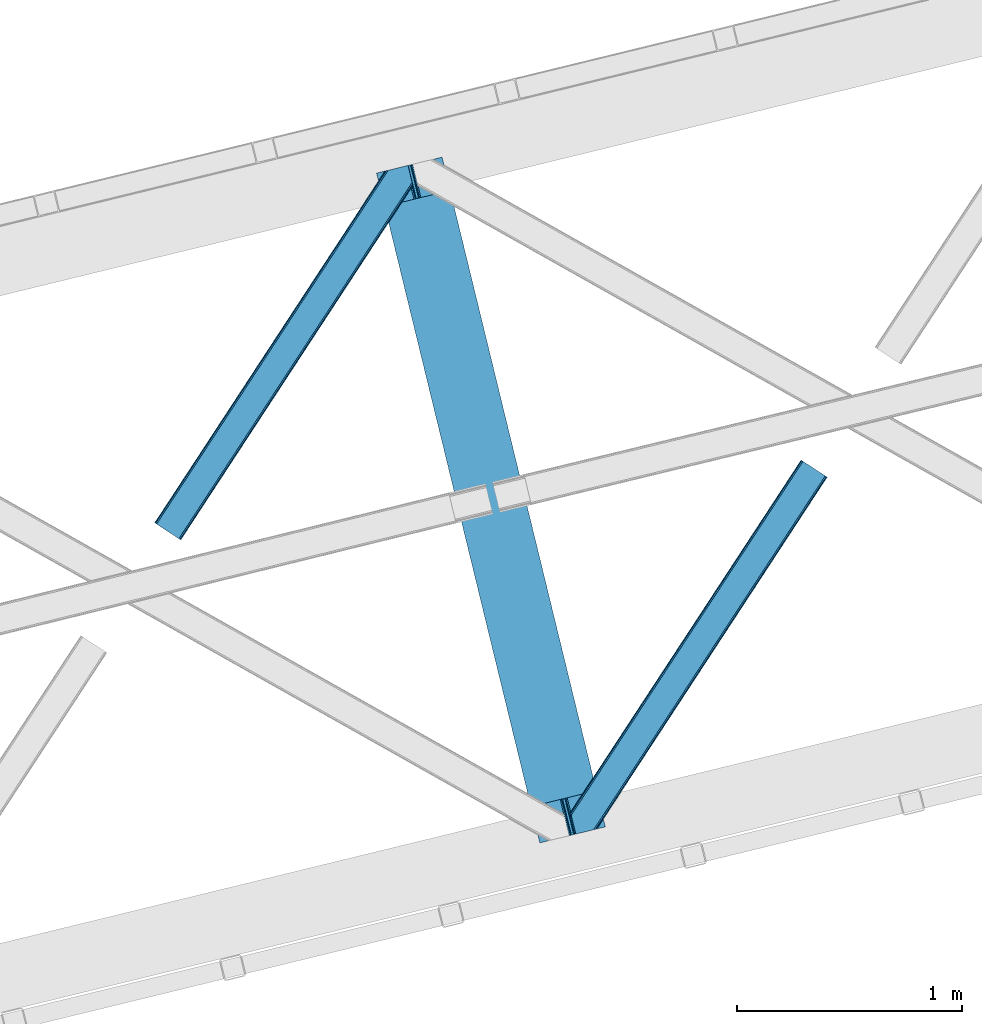
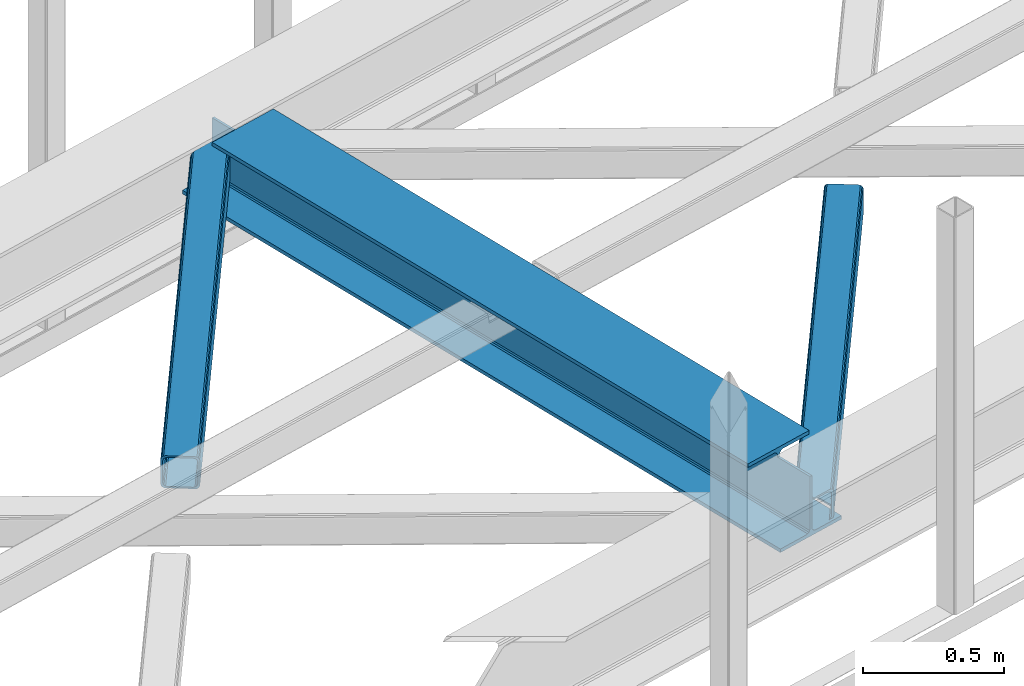
# One storey, part 27 of 66: 2 members, 1 beam.
"""IFC4 building model written with IfcOpenShell, lengths in millimetres."""

from ifc_helpers import new_model, entity, si_unit, converted_unit, derived_unit, direction, frame, origin, place, context, subcontext, project, spatial, triangles, polygons, material, type_object, element, save


model = new_model("IFC4")

# Units and contexts
model_context = context("Model", 3, precision=0.01, world=origin(), true_north=direction((6.12303176911189e-17, 1.0)))
plan_context = context("Plan", 3, precision=0.01, world=origin(), true_north=direction((6.12303176911189e-17, 1.0)))
body_context = subcontext(model_context, "Body", "Model", "MODEL_VIEW")
ifc_project = project(units=[si_unit("LENGTHUNIT", "METRE", prefix="MILLI"), si_unit("AREAUNIT", "SQUARE_METRE"), si_unit("VOLUMEUNIT", "CUBIC_METRE"), converted_unit("PLANEANGLEUNIT", "DEGREE", entity("IfcRatioMeasure", 0.0174532925199433), si_unit("PLANEANGLEUNIT", "RADIAN"), dimensions=[0, 0, 0, 0, 0, 0, 0]), si_unit("MASSUNIT", "GRAM", prefix="KILO"), derived_unit("MASSDENSITYUNIT", [(si_unit("MASSUNIT", "GRAM", prefix="KILO"), 1), (si_unit("LENGTHUNIT", "METRE"), -3)]), derived_unit("MOMENTOFINERTIAUNIT", [(si_unit("LENGTHUNIT", "METRE"), 4)]), si_unit("TIMEUNIT", "SECOND"), si_unit("FREQUENCYUNIT", "HERTZ"), si_unit("THERMODYNAMICTEMPERATUREUNIT", "DEGREE_CELSIUS"), derived_unit("THERMALTRANSMITTANCEUNIT", [(si_unit("MASSUNIT", "GRAM", prefix="KILO"), 1), (si_unit("THERMODYNAMICTEMPERATUREUNIT", "KELVIN"), -1), (si_unit("TIMEUNIT", "SECOND"), -3)]), derived_unit("VOLUMETRICFLOWRATEUNIT", [(si_unit("LENGTHUNIT", "METRE"), 3), (si_unit("TIMEUNIT", "SECOND"), -1)]), derived_unit("MASSFLOWRATEUNIT", [(si_unit("MASSUNIT", "GRAM", prefix="KILO"), 1), (si_unit("TIMEUNIT", "SECOND"), -1)]), derived_unit("ROTATIONALFREQUENCYUNIT", [(si_unit("TIMEUNIT", "SECOND"), -1)]), si_unit("ELECTRICCURRENTUNIT", "AMPERE"), si_unit("ELECTRICVOLTAGEUNIT", "VOLT"), si_unit("POWERUNIT", "WATT"), si_unit("FORCEUNIT", "NEWTON", prefix="KILO"), si_unit("ILLUMINANCEUNIT", "LUX"), si_unit("LUMINOUSFLUXUNIT", "LUMEN"), si_unit("LUMINOUSINTENSITYUNIT", "CANDELA"), derived_unit("USERDEFINED", [(si_unit("MASSUNIT", "GRAM", prefix="KILO"), -1), (si_unit("LENGTHUNIT", "METRE"), -2), (si_unit("TIMEUNIT", "SECOND"), 3), (si_unit("LUMINOUSFLUXUNIT", "LUMEN"), 1)]), derived_unit("LINEARVELOCITYUNIT", [(si_unit("LENGTHUNIT", "METRE"), 1), (si_unit("TIMEUNIT", "SECOND"), -1)]), si_unit("PRESSUREUNIT", "PASCAL"), derived_unit("USERDEFINED", [(si_unit("LENGTHUNIT", "METRE"), -2), (si_unit("MASSUNIT", "GRAM", prefix="KILO"), 1), (si_unit("TIMEUNIT", "SECOND"), -2)]), derived_unit("LINEARFORCEUNIT", [(si_unit("MASSUNIT", "GRAM", prefix="KILO"), 1), (si_unit("LENGTHUNIT", "METRE"), 1), (si_unit("TIMEUNIT", "SECOND"), -2), (si_unit("LENGTHUNIT", "METRE"), -1)]), derived_unit("PLANARFORCEUNIT", [(si_unit("MASSUNIT", "GRAM", prefix="KILO"), 1), (si_unit("LENGTHUNIT", "METRE"), 1), (si_unit("TIMEUNIT", "SECOND"), -2), (si_unit("LENGTHUNIT", "METRE"), -2)])], contexts=[model_context, plan_context])

# Site, building, storey
site_placement = place(None, origin())
site = spatial("IfcSite", under=ifc_project, at=site_placement, CompositionType="ELEMENT")
building_placement = place(site_placement, origin())
building = spatial("IfcBuilding", under=site, at=building_placement, CompositionType="ELEMENT")
storey_placement = place(building_placement, frame((0.0, 0.0, 19800.0)))
storey = spatial("IfcBuildingStorey", under=building, at=storey_placement, Name="06", CompositionType="ELEMENT", Elevation=19800.0)

# Beam
ifc_material = material(Name="Metal painted (White)")
beam_type = type_object("IfcBeamType", PredefinedType="BEAM")
beam_placement = place(storey_placement, frame((-46287.06, 6511.97, 3807.02)))
element("IfcBeam", 1, at=beam_placement, inside=storey, type_object=beam_type, material=ifc_material, ObjectType="Steel Beam", PredefinedType="BEAM", context=body_context, shape_type="Tessellation", body=[
    polygons([(1018.16648378329, 71.0478278971, 15.5000000000008), (1018.16648378329, 71.047827897101, 0.0), (291.465617442446, 3052.25531830421, 0.0), (291.465617442446, 3052.25531830421, 15.5000000000008), (894.779372399329, 40.970914087328, 15.5000000000008), (168.078506058474, 3022.17840449444, 15.5000000000008), (888.087028625375, 39.3395844888232, 16.8701684147984), (161.386162284528, 3020.54707489594, 16.8701684147984), (882.413533524759, 37.9566100336508, 20.7720779386434), (155.712667183904, 3019.16410044076, 20.7720779386434), (878.622625296184, 37.0325360459173, 26.6116982174294), (151.921758955329, 3018.24002645303, 26.6116982174294), (877.291435352779, 36.7080444135018, 33.500000000001), (150.590569011932, 3017.91553482061, 33.500000000001), (140.875048430522, 3015.54727389071, 33.500000000001), (140.875048430522, 3015.54727389071, 259.000000000002), (150.590569011932, 3017.91553482061, 259.000000000002), (8.66293703438714e-12, 2981.20749040711, 0.0), (8.66293703438714e-12, 2981.20749040711, 15.4999999999965), (123.387111383972, 3011.28440421689, 15.5000000000008), (130.079455157935, 3012.91573381539, 16.8701684147984), (135.752950258542, 3014.29870827056, 20.7720779386434), (139.543858487126, 3015.2227822583, 26.6116982174294), (877.291435352788, 36.7080444135029, 259.000000000002), (867.575914771378, 34.3397834835992, 259.000000000002), (867.575914771378, 34.3397834835992, 33.500000000001), (866.244724827981, 34.0152918511848, 26.6116982174294), (862.453816599397, 33.0912178634502, 20.7720779386434), (856.78032149879, 31.7082434082767, 16.8701684147984), (850.087977724828, 30.0769138097719, 15.5000000000008), (726.700866340864, 1.08286712929839e-12, 15.4999999999965), (726.700866340864, 1.08286712929839e-12, 0.0), (838.124523615921, 197.385937999178, 259.069791973884), (186.46972209998, 2870.72539801218, 259.000000000002), (186.69311520182, 2869.80895360721, 259.617303331124), (186.705504045446, 2869.75812937344, 266.500003008253), (837.979344808156, 197.981416001703, 266.500002998871), (837.979694928899, 197.979979696969, 260.000004007589), (828.499586345885, 194.64586594443, 259.006343171919), (828.27621632612, 195.562317481911, 259.617303331124), (828.263827482486, 195.613141715684, 266.500003008253), (176.989986719793, 2867.38985508742, 266.500002998871), (176.98963659904, 2867.39129139215, 260.000004007589), (176.844830940705, 2867.98534020594, 259.07612046749), (176.754201518561, 2868.35713708228, 259.000000000002), (839.310832678074, 198.304685446389, 273.388305639783), (843.10110926677, 199.231350618302, 279.227924098781), (848.774180214309, 200.616065081978, 283.129832400619), (855.466371895434, 202.248018612791, 284.500000377228), (978.853400583278, 232.325271667903, 284.500000138971), (978.851730776626, 232.332121736634, 299.999995328161), (687.386308679356, 161.283492472592, 299.999995890962), (687.387978486008, 161.276642403861, 284.500000701776), (810.775007173852, 191.353895458971, 284.500000463519), (817.467494069999, 192.984637925551, 283.129832461069), (823.141405718751, 194.365903570076, 279.227924137322), (826.932940505751, 195.287407219373, 273.388305663684), (175.658498849865, 2867.06658564273, 273.388305639783), (171.868222261161, 2866.13992047082, 279.227924098781), (166.195151313631, 2864.75520600714, 283.129832400619), (159.502959632506, 2863.12325247633, 284.500000377228), (36.1159309446533, 2833.04599942122, 284.500000138971), (36.1176007513137, 2833.03914935249, 299.999995328161), (327.583022848584, 2904.08777861653, 299.999995890962), (327.581353041932, 2904.09462868526, 284.500000701776), (204.19432435408, 2874.01737563015, 284.500000463519), (197.50183745795, 2872.38663316357, 283.129832461069), (191.827925809181, 2871.00536751905, 279.227924137322), (188.036391022189, 2870.08386386975, 273.388305663684)], [[[1, 2, 3, 4]], [[5, 1, 4, 6]], [[7, 5, 6, 8]], [[9, 7, 8, 10]], [[11, 9, 10, 12]], [[13, 11, 12, 14]], [[15, 16, 17, 14, 12, 10, 8, 6, 4, 3, 18, 19, 20, 21, 22, 23]], [[13, 24, 25, 26, 27, 28, 29, 30, 31, 32, 2, 1, 5, 7, 9, 11]], [[2, 32, 18, 3]], [[32, 31, 19, 18]], [[31, 30, 20, 19]], [[27, 26, 15, 23]], [[28, 27, 23, 22]], [[29, 28, 22, 21]], [[30, 29, 21, 20]], [[33, 24, 13, 14, 17, 34, 35, 36, 37, 38]], [[25, 39, 40, 41, 42, 43, 44, 16, 15, 26]], [[39, 25, 24, 33]], [[45, 34, 17, 16]], [[41, 40, 38, 37, 46, 47, 48, 49, 50, 51, 52, 53, 54, 55, 56, 57]], [[42, 58, 59, 60, 61, 62, 63, 64, 65, 66, 67, 68, 69, 36, 35, 43]], [[46, 37, 36, 69]], [[47, 46, 69, 68]], [[48, 47, 68, 67]], [[49, 48, 67, 66]], [[50, 49, 66, 65]], [[51, 50, 65, 64]], [[52, 51, 64, 63]], [[53, 52, 63, 62]], [[54, 53, 62, 61]], [[55, 54, 61, 60]], [[56, 55, 60, 59]], [[57, 56, 59, 58]], [[41, 57, 58, 42]]], closed=False),
])

# Members
member_type_1 = type_object("IfcMemberType", PredefinedType="BRACE")
member_1_placement = place(storey_placement, frame((-47275.26, 7859.97, 3824.0)))
element("IfcMember", 2, at=member_1_placement, inside=storey, type_object=member_type_1, ObjectType="Steel Horizontal Brace", PredefinedType="BRACE", context=body_context, shape_type="Tessellation", body=[
    triangles([(994.771838378903, 1564.02662658691, 0.0), (1028.82092285156, 1424.34736175537, 0.0), (14.6409667968692, 67.104043579101, 0.0), (102.482116699219, 9.58604278564417, 0.0), (1.11156005859084, 75.9604797363281, 10.8039916992202), (0.0, 76.6900863647461, 17.5012573242202), (1025.02580566406, 1642.17883300781, 17.5012573242202), (4.28811035156104, 73.8821182250977, 5.12526855468968), (990.474426269531, 1585.87703704834, 9.49942016601563), (990.041894531249, 1584.44747314453, 8.74132690429906), (989.907019042963, 1583.99226837158, 8.49948120117188), (990.758129882808, 1580.48841247559, 5.12526855468968), (1027.30473632812, 1642.73519439697, 10.8691040039084), (1027.77912597656, 1642.8503036499, 9.49942016601563), (992.599877929686, 1572.93538513184, 1.33247680664135), (9.03665771483793, 70.7724243164057, 1.33247680664135), (1025.02580566406, 1642.17883300781, 122.499499511719), (0.0, 76.6900863647461, 122.499499511719), (1026.9187133789, 1642.64101409912, 129.196765136719), (1.11156005859084, 75.9604797363281, 129.196765136719), (1032.31373291015, 1643.95605010986, 134.87548828125), (4.28811035156104, 73.8821182250977, 134.87548828125), (1040.39230957031, 1645.92395324707, 138.668280029298), (9.03665771483793, 70.7724243164057, 138.668280029298), (1049.91730957031, 1648.24590454102, 140.00075683594), (14.6409667968692, 67.104043579101, 140.00075683594), (994.869506835938, 1567.85139312744, 9.49942016601563), (994.757885742183, 1567.00667724609, 9.2947814941399), (994.646264648436, 1566.15091552734, 9.08781738281323), (994.539294433591, 1565.306199646, 8.8831787109375), (994.743933105463, 1564.14464263916, 8.49948120117188), (1047.05236816406, 1647.54827270508, 9.49942016601563), (14.892114257811, 66.9377746582031, 8.3320495605476), (20.4964233398423, 63.2693939208984, 6.99957275390625), (997.041467285155, 1554.71498565674, 6.99957275390625), (10.1435668945269, 70.0474685668942, 12.1248413085959), (1042.27126464844, 1646.3826461792, 12.1248413085959), (1036.87624511719, 1645.06761016846, 17.8035644531265), (1034.98333740234, 1644.60601043701, 24.5008300781265), (6.96701660155668, 72.1258300781246, 17.8035644531265), (5.85545654296584, 72.8554367065426, 24.5008300781265), (1026.55129394531, 1433.65958404541, 6.99957275390625), (96.6266601562456, 13.4206924438477, 6.99957275390625), (1028.71395263672, 1424.77640533447, 8.41343994140698), (1032.83463134765, 1407.88615722656, 5.12526855468968), (1033.6857421875, 1404.38230133057, 8.49948120117188), (1030.99288330078, 1415.43918457031, 1.33247680664135), (1034.98333740234, 1644.60601043701, 115.499926757813), (5.85545654296584, 72.8554367065426, 115.499926757813), (1050.34519042968, 1648.35113067627, 131.668707275392), (1059.87019042968, 1650.67308197021, 133.001184082033), (20.4964233398423, 63.2693939208984, 133.001184082033), (14.892114257811, 66.9377746582031, 131.668707275392), (1042.27126464844, 1646.3826461792, 127.873590087893), (10.1435668945269, 70.0474685668942, 127.873590087893), (1036.87624511719, 1645.06761016846, 122.197192382813), (6.96701660155668, 72.1258300781246, 122.197192382813), (1128.10788574218, 1667.30578765869, 140.00075683594), (1128.10788574218, 1667.30578765869, 133.001184082033), (1144.32550048828, 1600.75810546875, 140.00075683594), (102.482116699219, 9.58604278564417, 140.00075683594), (1142.05587158203, 1610.06974639893, 133.001184082033), (96.6266601562456, 13.4206924438477, 133.001184082033), (1146.4974609375, 1591.84934692383, 138.668280029298), (108.08642578125, 5.91766204833948, 138.668280029298), (1148.33920898437, 1584.29631958008, 134.87548828125), (112.834973144527, 2.80738677978479, 134.87548828125), (1149.57169189453, 1579.2501159668, 129.196765136719), (116.011523437497, 0.729606628417969, 129.196765136719), (1150.00422363281, 1577.47813110352, 122.499499511719), (117.123083496088, 0.0, 122.499499511719), (1150.00422363281, 1577.47813110352, 17.5012573242202), (117.123083496088, 0.0, 17.5012573242202), (106.979516601561, 6.64203643798828, 127.873590087893), (110.151416015622, 4.56425628662055, 122.197192382813), (111.267626953122, 3.83464965820258, 115.499926757813), (102.230969238277, 9.75231170654297, 131.668707275392), (116.011523437497, 0.729606628417969, 10.8039916992202), (106.979516601561, 6.64203643798828, 12.1248413085959), (112.834973144527, 2.80738677978479, 5.12526855468968), (111.267626953122, 3.83464965820258, 24.5008300781265), (110.151416015622, 4.56425628662055, 17.8035644531265), (108.08642578125, 5.91766204833948, 1.33247680664135), (102.230969238277, 9.75231170654297, 8.3320495605476), (1147.30206298828, 1588.56233825684, 122.197192382813), (1147.73459472656, 1586.78977203369, 115.499926757813), (1146.06958007813, 1593.60854187012, 127.873590087893), (1144.22783203125, 1601.160987854, 131.668707275392), (1147.73459472656, 1586.78977203369, 24.5008300781265), (1147.21369628906, 1588.9239440918, 17.8686767578147), (1149.994921875, 1577.51591949463, 16.5013183593765), (1147.10672607421, 1589.36519622803, 16.5013183593765), (1145.27427978515, 1573.10804901123, 10.8714294433594), (1034.61591796875, 1404.78809051514, 9.49942016601563), (1144.12551269531, 1572.03427734375, 9.49942016601563), (1142.79071044922, 1588.5978012085, 12.1248413085959), (1030.22548828125, 1422.8143157959, 9.49942016601563), (1029.19764404296, 1423.6724029541, 8.80643920898365), (1139.7304321289, 1590.05992126465, 9.49942016601563)], [[1, 2, 3], [4, 3, 2], [5, 6, 7], [8, 9, 10], [11, 12, 8], [5, 13, 9], [9, 8, 5], [13, 14, 9], [15, 1, 16], [3, 16, 1], [12, 15, 8], [16, 8, 15], [7, 13, 5], [17, 7, 18], [6, 18, 7], [19, 17, 20], [18, 20, 17], [21, 19, 22], [20, 22, 19], [23, 21, 24], [22, 24, 21], [25, 23, 26], [24, 26, 23], [27, 28, 9], [28, 29, 10], [29, 30, 10], [30, 31, 11], [14, 32, 27], [27, 9, 14], [33, 34, 35], [36, 33, 31], [31, 30, 36], [28, 36, 29], [28, 27, 36], [36, 30, 29], [32, 37, 27], [36, 27, 37], [35, 31, 33], [38, 39, 40], [41, 40, 39], [37, 38, 36], [40, 36, 38], [42, 35, 34], [34, 43, 42], [1, 35, 42], [31, 12, 11], [1, 31, 35], [31, 15, 12], [31, 1, 15], [2, 1, 42], [44, 2, 42], [45, 44, 46], [44, 47, 2], [44, 45, 47], [39, 48, 49], [49, 41, 39], [50, 51, 52], [52, 53, 50], [54, 50, 53], [53, 55, 54], [56, 54, 55], [55, 57, 56], [48, 56, 57], [57, 49, 48], [56, 17, 19], [50, 23, 25], [58, 51, 25], [51, 58, 59], [51, 50, 25], [54, 23, 50], [54, 56, 21], [21, 23, 54], [19, 21, 56], [39, 7, 17], [37, 14, 38], [56, 48, 17], [37, 32, 14], [39, 38, 7], [48, 39, 17], [13, 7, 38], [38, 14, 13], [60, 25, 61], [25, 60, 58], [26, 61, 25], [51, 62, 63], [51, 59, 62], [63, 52, 51], [64, 60, 61], [61, 65, 64], [66, 64, 65], [65, 67, 66], [68, 66, 67], [67, 69, 68], [70, 68, 69], [69, 71, 70], [72, 70, 71], [71, 73, 72], [69, 74, 75], [76, 73, 71], [69, 75, 71], [69, 67, 74], [75, 76, 71], [74, 67, 65], [63, 61, 26], [61, 77, 65], [77, 61, 63], [77, 74, 65], [78, 79, 80], [81, 73, 76], [73, 82, 78], [82, 73, 81], [78, 82, 79], [4, 43, 3], [83, 80, 79], [79, 84, 83], [84, 43, 4], [4, 83, 84], [55, 24, 22], [26, 52, 63], [26, 53, 52], [53, 26, 24], [55, 53, 24], [49, 18, 6], [20, 57, 55], [22, 20, 55], [57, 20, 18], [49, 57, 18], [16, 36, 8], [3, 43, 34], [34, 33, 3], [33, 36, 16], [16, 3, 33], [5, 8, 36], [6, 41, 49], [40, 6, 5], [6, 40, 41], [40, 5, 36], [85, 86, 75], [76, 75, 86], [87, 85, 74], [75, 74, 85], [88, 87, 77], [74, 77, 87], [62, 88, 63], [77, 63, 88], [86, 89, 76], [81, 76, 89], [90, 91, 92], [70, 72, 89], [72, 90, 89], [89, 86, 70], [72, 91, 90], [85, 70, 86], [68, 70, 85], [66, 85, 87], [85, 66, 68], [87, 64, 66], [88, 64, 87], [88, 62, 60], [88, 60, 64], [62, 58, 60], [62, 59, 58], [73, 78, 93], [93, 72, 73], [94, 93, 78], [94, 95, 93], [80, 45, 46], [46, 78, 80], [46, 94, 78], [47, 45, 83], [80, 83, 45], [2, 47, 4], [83, 4, 47], [93, 91, 72], [82, 81, 89], [82, 92, 96], [82, 90, 92], [84, 97, 98], [79, 96, 97], [97, 84, 79], [96, 99, 97], [43, 84, 44], [44, 42, 43], [96, 79, 82], [89, 90, 82], [96, 91, 93], [96, 92, 91], [96, 95, 99], [93, 95, 96], [99, 95, 97], [94, 97, 95]]),
])
member_type_2 = type_object("IfcMemberType", PredefinedType="BRACE")
member_2_placement = place(storey_placement, frame((-45423.94, 6551.04, 3824.0)))
element("IfcMember", 3, at=member_2_placement, inside=storey, type_object=member_type_2, ObjectType="Steel Horizontal Brace", PredefinedType="BRACE", context=body_context, shape_type="Tessellation", body=[
    triangles([(109.770043945318, 259.949830627442, 7.52047119140843), (115.030187988283, 238.365682983399, 7.77626953125218), (114.216284179689, 239.946981811524, 8.3320495605476), (108.811962890628, 259.662057495118, 8.52041015625218), (113.634924316408, 239.859196472168, 8.52041015625218), (112.20710449219, 237.677352905273, 8.52041015625218), (91.0363037109419, 232.516621398926, 8.52041015625218), (109.537500000006, 237.026229858398, 9.49942016601563), (90.2642578125015, 232.328260803223, 9.49942016601563), (5.02294921875, 77.405158996582, 9.49942016601563), (0.62786865234375, 95.4308029174808, 9.49942016601563), (1046.62448730469, 1651.75324859619, 6.99957275390625), (1041.02017822266, 1655.4216293335, 8.3320495605476), (116.699853515631, 231.514938354492, 6.99957275390625), (1036.27163085938, 1658.53190460205, 12.1248413085959), (3.92999267578125, 81.8752349853521, 12.1248413085959), (1033.09973144531, 1660.61026611328, 17.8035644531265), (2.70216064453416, 86.9220199584961, 17.8035644531265), (1031.98352050781, 1661.3398727417, 24.5008300781265), (2.26962890625146, 88.6940048217775, 24.5008300781265), (1122.7547241211, 1601.90454711914, 6.99957275390625), (146.209680175787, 110.459536743164, 6.99957275390625), (1031.98352050781, 1661.3398727417, 115.499926757813), (2.26962890625146, 88.6940048217775, 115.499926757813), (1033.09973144531, 1660.61026611328, 122.197192382813), (2.70216064453416, 86.9220199584961, 122.197192382813), (1036.27163085938, 1658.53190460205, 127.873590087893), (3.92999267578125, 81.8752349853521, 127.873590087893), (1041.02017822266, 1655.4216293335, 131.668707275392), (5.77174072265916, 74.322789001465, 131.668707275392), (1046.62448730469, 1651.75324859619, 133.001184082033), (7.94370117187646, 65.4140304565435, 133.001184082033), (1027.24427490235, 1664.44433441162, 10.8039916992202), (0.520898437505821, 95.8714736938482, 10.8691040039084), (0.0, 98.0056457519531, 17.5012573242202), (1035.16472167969, 1659.2562789917, 1.33247680664135), (112.258264160162, 249.73533782959, 1.33247680664135), (110.546740722661, 256.772117614746, 5.59500732422021), (109.077062988283, 259.839372253418, 8.32042236328198), (1030.41617431641, 1662.36655426025, 5.12526855468968), (1040.76903076172, 1655.58789825439, 0.0), (114.430224609379, 240.826579284668, 0.0), (1026.12806396485, 1665.1745223999, 17.5012573242202), (1128.61018066407, 1598.06989746094, 0.0), (148.479309082031, 101.147314453126, 0.0), (150.651269531256, 92.2385559082031, 1.33247680664135), (148.507214355472, 101.029298400879, 8.49948120117188), (152.493017578126, 84.686109924317, 5.12526855468968), (153.348779296881, 81.1822540283201, 8.49948120117188), (1026.12806396485, 1665.1745223999, 122.499499511719), (0.0, 98.0056457519531, 122.499499511719), (1040.76903076172, 1655.58789825439, 140.00075683594), (1035.16472167969, 1659.2562789917, 138.668280029298), (3.50211181640771, 83.6350112915043, 138.668280029298), (5.674072265625, 74.7256713867191, 140.00075683594), (1030.41617431641, 1662.36655426025, 134.87548828125), (1.66036376953707, 91.1874572753904, 134.87548828125), (1027.24427490235, 1664.44433441162, 129.196765136719), (0.432531738282705, 96.2336608886717, 129.196765136719), (23.8915649414121, 0.0, 140.00075683594), (23.8915649414121, 0.0, 133.001184082033), (1128.61018066407, 1598.06989746094, 140.00075683594), (93.3338378906265, 16.9280364990236, 140.00075683594), (1122.7547241211, 1601.90454711914, 133.001184082033), (83.3809570312515, 14.501440429688, 133.001184082033), (1143.25579833984, 1588.48385467529, 122.499499511719), (1142.13958740234, 1589.21346130371, 129.196765136719), (118.225341796875, 22.9951080322271, 122.499499511719), (116.332434082033, 22.5335083007813, 129.196765136719), (1138.96303710938, 1591.29124145508, 134.87548828125), (110.937414550783, 21.2178909301756, 134.87548828125), (1134.2144897461, 1594.40151672363, 138.668280029298), (102.858837890628, 19.2499877929686, 138.668280029298), (1143.25579833984, 1588.48385467529, 17.5012573242202), (118.225341796875, 22.9951080322271, 17.5012573242202), (1142.13958740234, 1589.21346130371, 10.8039916992202), (1133.10758056641, 1595.12647247314, 12.1248413085959), (1136.28413085938, 1593.04811096191, 17.8035644531265), (1137.39569091797, 1592.3185043335, 24.5008300781265), (1138.96303710938, 1591.29124145508, 5.12526855468968), (1134.2144897461, 1594.40151672363, 1.33247680664135), (1128.35903320313, 1598.23616638184, 8.3320495605476), (1133.10758056641, 1595.12647247314, 127.873590087893), (1137.39569091797, 1592.3185043335, 115.499926757813), (1136.28413085938, 1593.04811096191, 122.197192382813), (1128.35903320313, 1598.23616638184, 131.668707275392), (92.9059570312529, 16.8228103637693, 131.668707275392), (100.979882812506, 18.79129486084, 127.873590087893), (106.374902343756, 20.106330871582, 122.197192382813), (108.267810058598, 20.5685119628906, 115.499926757813), (108.267810058598, 20.5685119628906, 24.5008300781265), (100.979882812506, 18.79129486084, 12.1248413085959), (115.472021484376, 22.32421875, 9.49942016601563), (106.374902343756, 20.106330871582, 17.8035644531265), (96.1987792968794, 17.6262496948248, 9.49942016601563), (115.946411132813, 22.4393280029299, 10.8691040039084), (153.060424804688, 80.2392883300781, 8.99945068359375), (152.776721191411, 79.2969039916998, 9.49942016601563), (148.711853027344, 99.8677413940432, 8.8831787109375), (148.604882812506, 99.023606872559, 9.08781738281323), (148.493261718751, 98.1672637939455, 9.2947814941399), (148.381640625004, 97.3225479125977, 9.49942016601563)], [[1, 2, 3], [4, 5, 6], [6, 7, 4], [7, 6, 8], [8, 9, 7], [9, 8, 10], [10, 11, 9], [12, 13, 3], [3, 2, 12], [2, 14, 12], [15, 16, 8], [8, 13, 15], [8, 5, 13], [16, 10, 8], [8, 6, 5], [15, 17, 18], [18, 16, 15], [17, 19, 20], [20, 18, 17], [21, 12, 14], [14, 22, 21], [19, 23, 20], [24, 20, 23], [23, 25, 24], [26, 24, 25], [25, 27, 26], [28, 26, 27], [27, 29, 28], [30, 28, 29], [29, 31, 30], [32, 30, 31], [33, 34, 35], [36, 37, 38], [33, 4, 9], [33, 1, 39], [9, 34, 33], [9, 11, 34], [4, 7, 9], [40, 38, 1], [1, 33, 40], [38, 40, 36], [36, 41, 37], [42, 37, 41], [35, 43, 33], [41, 44, 42], [45, 42, 44], [14, 42, 22], [37, 2, 38], [2, 37, 42], [38, 2, 1], [42, 14, 2], [22, 42, 45], [46, 47, 45], [47, 46, 48], [45, 47, 22], [48, 49, 47], [50, 43, 35], [35, 51, 50], [52, 53, 54], [54, 55, 52], [53, 56, 57], [57, 54, 53], [56, 58, 59], [59, 57, 56], [58, 50, 51], [51, 59, 58], [28, 57, 26], [30, 32, 55], [32, 60, 55], [32, 61, 60], [54, 30, 55], [28, 54, 57], [16, 11, 10], [28, 30, 54], [51, 35, 20], [24, 26, 51], [24, 51, 20], [57, 59, 26], [26, 59, 51], [35, 18, 20], [18, 11, 16], [11, 18, 34], [35, 34, 18], [62, 55, 63], [62, 52, 55], [55, 60, 63], [64, 32, 31], [32, 64, 65], [61, 32, 65], [66, 67, 68], [69, 68, 67], [67, 70, 69], [71, 69, 70], [70, 72, 71], [73, 71, 72], [72, 62, 73], [63, 73, 62], [74, 66, 75], [68, 75, 66], [76, 77, 78], [79, 66, 74], [76, 78, 74], [76, 80, 77], [78, 79, 74], [77, 80, 81], [21, 44, 41], [44, 82, 81], [82, 44, 21], [82, 77, 81], [67, 83, 70], [84, 66, 79], [66, 85, 67], [85, 66, 84], [67, 85, 83], [62, 64, 52], [72, 70, 83], [83, 86, 72], [86, 64, 62], [62, 72, 86], [15, 36, 40], [41, 12, 21], [41, 13, 12], [13, 41, 36], [15, 13, 36], [19, 43, 50], [33, 17, 15], [40, 33, 15], [17, 33, 43], [19, 17, 43], [53, 27, 56], [52, 64, 31], [31, 29, 52], [29, 27, 53], [53, 52, 29], [58, 56, 27], [50, 23, 19], [25, 50, 58], [50, 25, 23], [25, 58, 27], [64, 86, 87], [87, 65, 64], [86, 83, 88], [88, 87, 86], [83, 85, 89], [89, 88, 83], [85, 84, 90], [90, 89, 85], [84, 79, 91], [91, 90, 84], [89, 68, 69], [87, 73, 63], [60, 65, 63], [65, 60, 61], [65, 87, 63], [88, 73, 87], [88, 89, 71], [71, 73, 88], [69, 71, 89], [91, 75, 68], [92, 93, 94], [89, 90, 68], [92, 95, 93], [91, 94, 75], [90, 91, 68], [96, 75, 94], [94, 93, 96], [76, 74, 75], [49, 80, 97], [98, 97, 80], [49, 48, 80], [76, 96, 98], [98, 80, 76], [96, 93, 98], [44, 81, 45], [46, 45, 81], [81, 80, 46], [48, 46, 80], [75, 96, 76], [82, 21, 22], [77, 82, 47], [47, 99, 77], [77, 100, 101], [100, 77, 99], [101, 102, 77], [77, 102, 92], [95, 92, 102], [22, 47, 82], [79, 78, 91], [94, 91, 78], [78, 77, 94], [92, 94, 77], [102, 101, 98], [101, 100, 97], [100, 99, 49], [99, 47, 49], [102, 98, 93], [93, 95, 102]]),
])

save(model, "model.ifc")
